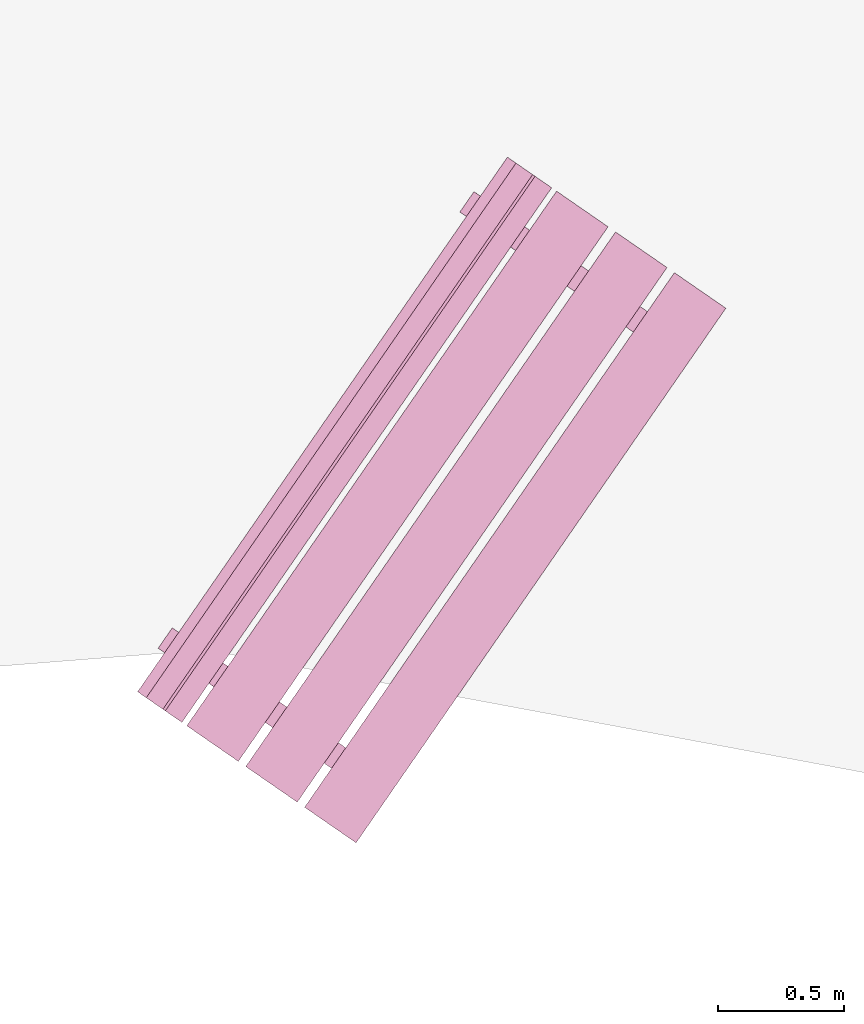
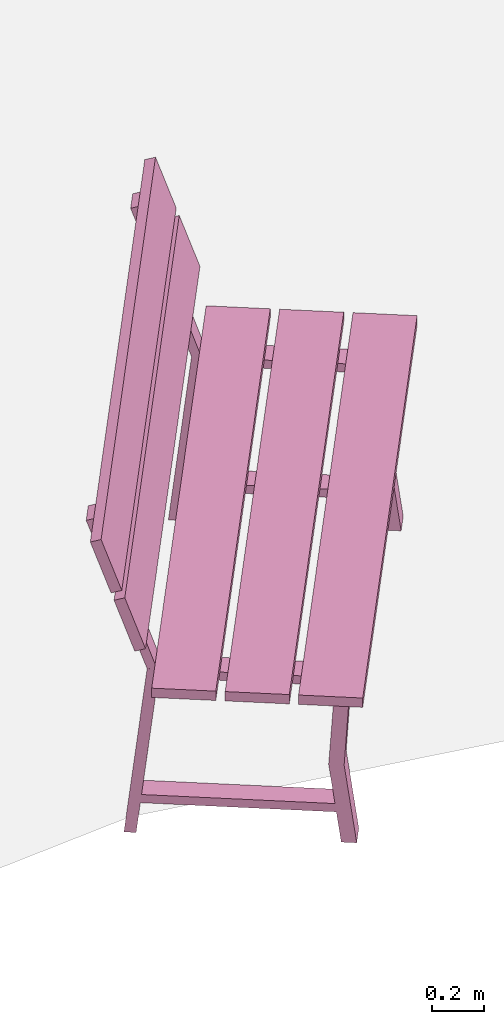
# One storey, part 13 of 200: 1 furnishing.
"""IFC4 building model written with IfcOpenShell, lengths in metres."""

import ifcopenshell
import ifcopenshell.guid

model = None  # the IFC model being written
_history = None  # IfcOwnerHistory: only IFC2X3 demands one
_inside = {}  # id of a spatial element -> (the spatial element, [elements in it])
_under = {}  # id of a project, library or spatial element -> (it, [spatial elements below it])
_declared = {}  # id of a project -> (the project, [libraries it declares])
_typed = {}  # id of a type object -> (the type object, [elements of that type])
_made_of = {}  # id of a material, layer set ... -> (it, [elements and type objects made of it])


def new_model(schema):
    """Start an empty IFC model of exactly this schema.

    Asked for "IFC4X3", IfcOpenShell would pick the latest addendum, in which some entities
    have other attributes; the version numbers below select the first issue.
    IFC2X3 requires an IfcOwnerHistory on every rooted entity: one is made here for all.
    """
    global model, _history
    if schema == "IFC4X3":
        model = ifcopenshell.file(schema_version=(4, 3, 0, 0))
    else:
        model = ifcopenshell.file(schema=schema)
    _inside.clear()
    _under.clear()
    _declared.clear()
    _typed.clear()
    _made_of.clear()
    _history = None
    if model.schema == "IFC2X3":
        org = make("IfcOrganization", Name="unknown")
        user = make(
            "IfcPersonAndOrganization",
            ThePerson=make("IfcPerson", FamilyName="unknown"),
            TheOrganization=org,
        )
        app = make(
            "IfcApplication",
            ApplicationDeveloper=org,
            Version="unknown",
            ApplicationFullName="unknown",
            ApplicationIdentifier="unknown",
        )
        _history = make(
            "IfcOwnerHistory",
            OwningUser=user,
            OwningApplication=app,
            ChangeAction="ADDED",
            CreationDate=0,
        )
    return model


def make(cls, **values):
    """One entity of the class cls with the attributes given. An attribute that is None is left unset."""
    return model.create_entity(
        cls, **{name: value for name, value in values.items() if value is not None}
    )


def rooted(cls, **values):
    """An entity with a GlobalId (a new one), such as an element, a storey or a relation."""
    return make(cls, GlobalId=ifcopenshell.guid.new(), OwnerHistory=_history, **values)


def si_unit(unit_type, name, prefix=None):
    """IfcSIUnit, for example si_unit("LENGTHUNIT", "METRE", prefix="MILLI")."""
    return make("IfcSIUnit", UnitType=unit_type, Prefix=prefix, Name=name)


def assignment(units):
    """IfcUnitAssignment: the units of a project."""
    return None if units is None else make("IfcUnitAssignment", Units=units)


def point(xyz):
    """IfcCartesianPoint."""
    return None if xyz is None else make("IfcCartesianPoint", Coordinates=xyz)


def direction(xyz):
    """IfcDirection."""
    return None if xyz is None else make("IfcDirection", DirectionRatios=xyz)


def frame(location, z_axis=None, x_axis=None):
    """IfcAxis2Placement3D, a coordinate frame: its origin and axes. An axis left out is left unset."""
    return make(
        "IfcAxis2Placement3D",
        Location=point(location),
        Axis=direction(z_axis),
        RefDirection=direction(x_axis),
    )


def origin_with_axes():
    """The frame at (0, 0, 0) with the z axis (0, 0, 1) and the x axis (1, 0, 0) written out."""
    return frame((0.0, 0.0, 0.0), z_axis=(0.0, 0.0, 1.0), x_axis=(1.0, 0.0, 0.0))


def place(relative_to, where):
    """IfcLocalPlacement: puts the frame where relative to a parent placement (None: the world)."""
    return make(
        "IfcLocalPlacement", PlacementRelTo=relative_to, RelativePlacement=where
    )


def context(
    kind, dimensions, precision=None, world=None, true_north=None, identifier=None
):
    """IfcGeometricRepresentationContext, for example the 3D "Model" context."""
    return make(
        "IfcGeometricRepresentationContext",
        ContextIdentifier=identifier,
        ContextType=kind,
        CoordinateSpaceDimension=dimensions,
        Precision=precision,
        WorldCoordinateSystem=world,
        TrueNorth=true_north,
    )


def subcontext(parent, identifier, kind, view, scale=None):
    """IfcGeometricRepresentationSubContext, for example "Body" below "Model"."""
    return make(
        "IfcGeometricRepresentationSubContext",
        ContextIdentifier=identifier,
        ContextType=kind,
        ParentContext=parent,
        TargetScale=scale,
        TargetView=view,
    )


def project(units=None, contexts=None):
    """IfcProject with its units and contexts."""
    return rooted(
        "IfcProject",
        Name="project",
        RepresentationContexts=contexts,
        UnitsInContext=assignment(units),
    )


def spatial(cls, under=None, at=None, **own):
    """A site, building, storey or space (cls), placed at a placement, below another one or the project."""
    s = rooted(cls, ObjectPlacement=at, **own)
    if under is not None:
        _under.setdefault(under.id(), (under, []))[1].append(s)
    return s


def point_list(points):
    """IfcCartesianPointList2D or 3D."""
    cls = (
        "IfcCartesianPointList2D" if len(points[0]) == 2 else "IfcCartesianPointList3D"
    )
    return make(cls, CoordList=points)


def triangles(points, corners, closed=None, point_numbers=None):
    """IfcTriangulatedFaceSet: each triangle names its three corners, points numbered from 1."""
    return make(
        "IfcTriangulatedFaceSet",
        Coordinates=point_list(points),
        Closed=closed,
        CoordIndex=corners,
        PnIndex=point_numbers,
    )


def shape(context_of_items, identifier, shape_type, items):
    """IfcShapeRepresentation: the items that make up one representation, for example the "Body"."""
    return make(
        "IfcShapeRepresentation",
        ContextOfItems=context_of_items,
        RepresentationIdentifier=identifier,
        RepresentationType=shape_type,
        Items=items,
    )


def material(Name=None, Category=None):
    """IfcMaterial."""
    return make("IfcMaterial", Name=Name, Category=Category)


def made_of(thing, what):
    """Note that an element or type object is made of a material, layer set ...; save() writes the relation."""
    if what is not None:
        _made_of.setdefault(what.id(), (what, []))[1].append(thing)
    return thing


def element(
    cls,
    number,
    at=None,
    inside=None,
    cuts=None,
    type_object=None,
    material=None,
    context=None,
    identifier="Body",
    shape_type=None,
    held_by="IfcProductDefinitionShape",
    body=None,
    shapes=None,
    **own,
):
    """One element of the class cls, such as IfcWall. Its Tag is "e" and its number.

    at: its placement. inside: the storey or other place that contains it. cuts: it is an
    opening in that element (IfcRelVoidsElement). A single representation is given by context,
    identifier, shape_type and body (its items); several are given by shapes. held_by: the class
    of the entity that holds the representations. save() writes the other relations.
    """
    e = rooted(cls, Tag="e%d" % number, ObjectPlacement=at, **own)
    if body is not None:
        shapes = [shape(context, identifier, shape_type, body)]
    if shapes is not None:
        e.Representation = make(held_by, Representations=shapes)
    if inside is not None:
        _inside.setdefault(inside.id(), (inside, []))[1].append(e)
    if cuts is not None:
        rooted(
            "IfcRelVoidsElement", RelatingBuildingElement=cuts, RelatedOpeningElement=e
        )
    if type_object is not None:
        _typed.setdefault(type_object.id(), (type_object, []))[1].append(e)
    return made_of(e, material)


def aggregate(whole, parts):
    """IfcRelAggregates: a whole, such as a stair, and the parts it consists of."""
    return rooted("IfcRelAggregates", RelatingObject=whole, RelatedObjects=parts)


def save(model, path):
    """Write the relations noted so far, then the file.

    IfcRelAggregates (storeys below a building ...), IfcRelContainedInSpatialStructure (elements
    in a storey), IfcRelDefinesByType, IfcRelAssociatesMaterial and IfcRelDeclares: one each for
    every whole, place, type object, material and project.
    """
    for whole, parts in _under.values():
        aggregate(whole, parts)
    for where, things in _inside.values():
        rooted(
            "IfcRelContainedInSpatialStructure",
            RelatedElements=things,
            RelatingStructure=where,
        )
    for kind, things in _typed.values():
        rooted("IfcRelDefinesByType", RelatedObjects=things, RelatingType=kind)
    for what, things in _made_of.values():
        rooted("IfcRelAssociatesMaterial", RelatedObjects=things, RelatingMaterial=what)
    for by, libraries in _declared.values():
        rooted("IfcRelDeclares", RelatingContext=by, RelatedDefinitions=libraries)
    model.write(path)


model = new_model("IFC4")

# Units and contexts
model_context = context("Model", 3, precision=1e-05, world=origin_with_axes())
body_context = subcontext(model_context, "Body", "Model", "MODEL_VIEW")
ifc_project = project(units=[si_unit("VOLUMEUNIT", "CUBIC_METRE"), si_unit("LENGTHUNIT", "METRE"), si_unit("AREAUNIT", "SQUARE_METRE")], contexts=[model_context])

# Site, building, storey
site_placement = place(None, origin_with_axes())
site = spatial("IfcSite", under=ifc_project, at=site_placement)
building_placement = place(site_placement, origin_with_axes())
building = spatial("IfcBuilding", under=site, at=building_placement, Name="Building")
storey_placement = place(building_placement, origin_with_axes())
storey = spatial("IfcBuildingStorey", under=building, at=storey_placement, Name="Ground")

# Furnishing
ifc_material = material(Name="bench")
furnishing_placement = place(storey_placement, origin_with_axes())
element("IfcFurnishingElement", 1, at=furnishing_placement, inside=storey, material=ifc_material, Name="cw_instances_bench_30", context=body_context, shape_type="Tessellation", body=[
    triangles([(433.6776323082832, -707.4828201764276, 0.815520754558246), (433.47344040222686, -707.3415949374371, 0.815520754558246), (432.0061604835972, -709.4630760936723, 0.815520754558246), (432.21035238965356, -709.6043013326628, 0.815520754558246), (432.4300447091276, -709.5270622097593, 0.36316797911391596), (432.4859863170098, -709.4461784837131, 0.36316797911391596), (432.52616392003955, -709.4739665175266, 1.4462435886752271e-07), (432.4702223121574, -709.5548502435728, 1.4462435886752271e-07), (432.5352831299738, -709.4802736362917, 0.36316797911391596), (432.51938698851654, -709.5888540065172, 1.6069373207502523e-07), (432.57532859639866, -709.507970280471, 1.6069373207502523e-07), (432.4793415220916, -709.5611573623379, 0.36316797911391596), (431.908433777329, -709.0467258461365, 0.7742224172068448), (431.908433777329, -709.0467258461365, 0.7742224172068448), (431.83455474513215, -708.9956288943528, 0.0), (431.77861313725, -709.076512620399, 0.0), (431.77861313725, -709.076512620399, 0.0), (431.85221795484034, -709.1280060480786, 0.7742224172068448), (431.943456995466, -709.0709489529537, 0.7346917591163886), (431.81733693365163, -709.1032951579983, 1.6069373207502518e-08), (431.8732785415338, -709.0224114319522, 1.6069373207502518e-08), (431.8875153875839, -709.1518326789999, 0.7353345501140619), (432.44986912509427, -709.5407733697009, 0.7353346465303011), (432.5060750590513, -709.4600724594862, 0.7346918555326278), (432.55576833469496, -709.4944418175306, 0.7742225618312036), (432.4995525122063, -709.5757220194728, 0.7742225618312036), (433.9111643822179, -707.6443379544353, 0.8155208509744852), (433.7069724893779, -707.5031127245855, 0.815520754558246), (432.2396925707483, -709.6245938808207, 0.815520754558246), (432.4438844635883, -709.7658191106705, 0.8155208509744852), (433.4437037188036, -707.321028156391, 0.815520754558246), (433.2395118259635, -707.1798029265412, 0.8155206581420068), (431.7722319073339, -709.3012840827764, 0.8155206581420068), (431.9764238001739, -709.4425093126262, 0.815520754558246), (433.21995168320655, -707.166274545868, 0.9999971268416286), (431.6867223560307, -709.2421431155756, 1.2349312667190762), (431.7526717645769, -709.2877557021031, 0.9999971268416286), (433.15400227466034, -707.1206619593404, 1.2349312667190762), (433.1444865227486, -707.1140805802648, 1.2691590637898031), (431.6112572220053, -709.1899491682541, 1.5040931072510113), (431.6772066041189, -709.2355617365, 1.2691590637898031), (433.0785371406349, -707.0684680120188, 1.5040931072510113), (431.65838533821056, -708.9935548956125, 1.4584561837579435), (431.71432700093743, -708.9126710902685, 1.4584561837579435), (431.908433777329, -709.0467258461365, 0.7742224172068448), (431.85221795484034, -709.1280060480786, 0.7742224172068448), (431.88407913539424, -709.1494560640493, 0.7739010297426947), (431.9396242673804, -709.0682981233967, 0.7739010297426947), (431.74564964081003, -708.9343347663038, 1.4724364581016047), (431.69010445397913, -709.0154927862542, 1.4724364581016047), (431.71844152466446, -709.2640810427804, 0.9858560302109066), (431.6526242659394, -709.2185598550278, 1.2207902665045935), (433.1857214432941, -707.1425998865452, 0.9858560302109066), (433.119904184569, -707.0970786987926, 1.2207902665045935), (431.64297637742277, -709.2118870863181, 1.2550180635753205), (431.57702698209283, -709.1662745089313, 1.4899522998690073), (433.1102562960524, -707.0904059300829, 1.2550180635753205), (433.04430690072246, -707.0447933526962, 1.4899522998690073), (433.62721419098153, -707.7961228952316, 0.36316797911391596), (433.6831557988637, -707.7152391691855, 0.36316797911391596), (433.7233334018934, -707.743027202999, 1.4462435886752271e-07), (433.6673917940113, -707.8239109290452, 1.4462435886752271e-07), (433.7324526118277, -707.7493343217641, 0.36316797911391596), (433.7165564703704, -707.8579146919895, 1.6069373207502523e-07), (433.77249807825257, -707.7770309659435, 1.6069373207502523e-07), (433.6765110039455, -707.8302180478103, 0.36316797911391596), (433.10560325918283, -707.3157865316089, 0.7742224172068448), (433.10560325918283, -707.3157865316089, 0.7742224172068448), (433.03172422698606, -707.2646895798251, 0.0), (432.9757826191039, -707.3455733058713, 0.0), (432.9757826191039, -707.3455733058713, 0.0), (433.0494788080468, -707.3969346233788, 0.7742224172068448), (433.1406264773199, -707.3400096384262, 0.7346917591163886), (433.01450641550554, -707.3723558434707, 1.6069373207502518e-08), (433.07044802338766, -707.2914721174245, 1.6069373207502518e-08), (433.08468486943775, -707.4208933644724, 0.7353345501140619), (433.6470386069482, -707.8098340551734, 0.7353346465303011), (433.7032445409052, -707.7291331449587, 0.7346918555326278), (433.75293781654887, -707.763502503003, 0.7742225618312036), (433.6968133654128, -707.8446505947729, 0.7742225618312036), (432.85564624626176, -707.2624833916149, 1.4584561837579435), (432.91149649193216, -707.1817317625247, 1.4584561837579435), (433.10560325918283, -707.3157865316089, 0.7742224172068448), (433.0494788080468, -707.3969346233788, 0.7742224172068448), (433.0812486172481, -707.4185167495218, 0.7739010297426947), (433.13679374923424, -707.3373588088691, 0.7739010297426947), (432.9428191318047, -707.2033954385598, 1.4724364581016047), (432.8873653620303, -707.2844212822566, 1.4724364581016047), (433.47344040222686, -707.3415949374371, 0.815520754558246), (432.0061604835972, -709.4630760936723, 0.7716513657017641), (432.0061604835972, -709.4630760936723, 0.815520754558246), (433.47344040222686, -707.3415949374371, 0.7716513657017641), (433.6776323082832, -707.4828201764276, 0.7716514139098837), (432.21035238965356, -709.6043013326628, 0.815520754558246), (432.21035238965356, -709.6043013326628, 0.7716514139098837), (433.6776323082832, -707.4828201764276, 0.815520754558246), (432.4702223121574, -709.5548502435728, 1.4462435886752271e-07), (432.4793415220916, -709.5611573623379, 0.36316797911391596), (432.4300447091276, -709.5270622097593, 0.36316797911391596), (432.51938698851654, -709.5888540065172, 1.6069373207502523e-07), (431.8875153875839, -709.1518326789999, 0.7353345501140619), (431.85221795484034, -709.1280060480786, 0.7742224172068448), (431.77861313725, -709.076512620399, 0.0), (431.81733693365163, -709.1032951579983, 1.6069373207502518e-08), (432.5352831299738, -709.4802736362917, 0.36316797911391596), (432.4859863170098, -709.4461784837131, 0.36316797911391596), (432.5060750590513, -709.4600724594862, 0.7346918555326278), (432.55576833469496, -709.4944418175306, 0.7742225618312036), (431.908433777329, -709.0467258461365, 0.7742224172068448), (431.943456995466, -709.0709489529537, 0.7346917591163886), (431.83455474513215, -708.9956288943528, 0.0), (431.8732785415338, -709.0224114319522, 1.6069373207502518e-08), (432.44986912509427, -709.5407733697009, 0.7353346465303011), (432.4995525122063, -709.5757220194728, 0.7742225618312036), (432.52616392003955, -709.4739665175266, 1.4462435886752271e-07), (432.57532859639866, -709.507970280471, 1.6069373207502523e-07), (431.65838533821056, -708.9935548956125, 1.4584561837579435), (431.74564964081003, -708.9343347663038, 1.4724364581016047), (431.71432700093743, -708.9126710902685, 1.4584561837579435), (431.69010445397913, -709.0154927862542, 1.4724364581016047), (431.8818900723114, -709.0297351090359, 0.13996424063734697), (431.8818900723114, -709.0297351090359, 0.17949489872780322), (432.5186515734662, -709.4701384380284, 0.13996438526170585), (432.5190480757948, -709.4704126709164, 0.17949504335216207), (431.8270453228552, -709.109032931498, 0.17949489872780322), (431.82722816610914, -709.1087685657742, 0.1406070155656471), (432.4637253544053, -709.5489890880759, 0.14060716019000596), (432.46420332633863, -709.5497104933786, 0.17949504335216207), (433.7069724893779, -707.5031127245855, 0.815520754558246), (432.2396925707483, -709.6245938808207, 0.7716514139098837), (432.2396925707483, -709.6245938808207, 0.815520754558246), (433.7069724893779, -707.5031127245855, 0.7716514139098837), (433.9111643822179, -707.6443379544353, 0.7716514621180032), (432.4438844635883, -709.7658191106705, 0.8155208509744852), (432.4438844635883, -709.7658191106705, 0.7716514621180032), (433.9111643822179, -707.6443379544353, 0.8155208509744852), (433.2395118259635, -707.1798029265412, 0.8155206581420068), (431.7722319073339, -709.3012840827764, 0.7716513174936444), (431.7722319073339, -709.3012840827764, 0.8155206581420068), (433.2395118259635, -707.1798029265412, 0.7716513174936444), (433.44370373201986, -707.3210281655317, 0.7716513657017641), (431.9764238001739, -709.4425093126262, 0.815520754558246), (431.9764238133902, -709.4425093217669, 0.7716513657017641), (433.4437037188036, -707.321028156391, 0.815520754558246), (431.6526242659394, -709.2185598550278, 1.2207902665045935), (433.15400227466034, -707.1206619593404, 1.2349312667190762), (433.119904184569, -707.0970786987926, 1.2207902665045935), (431.6867223560307, -709.2421431155756, 1.2349312667190762), (433.1857214432941, -707.1425998865452, 0.9858560302109066), (431.7526717645769, -709.2877557021031, 0.9999971268416286), (431.71844152466446, -709.2640810427804, 0.9858560302109066), (433.21995168320655, -707.166274545868, 0.9999971268416286), (431.57702698209283, -709.1662745089313, 1.4899522998690073), (433.0785371406349, -707.0684680120188, 1.5040931072510113), (433.04430690072246, -707.0447933526962, 1.4899522998690073), (431.6112572220053, -709.1899491682541, 1.5040931072510113), (433.1102562960524, -707.0904059300829, 1.2550180635753205), (431.6772066041189, -709.2355617365, 1.2691590637898031), (431.64297637742277, -709.2118870863181, 1.2550180635753205), (433.1444865227486, -707.1140805802648, 1.2691590637898031), (433.6673917940113, -707.8239109290452, 1.4462435886752271e-07), (433.6765110039455, -707.8302180478103, 0.36316797911391596), (433.62721419098153, -707.7961228952316, 0.36316797911391596), (433.7165564703704, -707.8579146919895, 1.6069373207502523e-07), (433.08468486943775, -707.4208933644724, 0.7353345501140619), (433.0494788080468, -707.3969346233788, 0.7742224172068448), (432.9757826191039, -707.3455733058713, 0.0), (433.01450641550554, -707.3723558434707, 1.6069373207502518e-08), (433.7324526118277, -707.7493343217641, 0.36316797911391596), (433.6831557988637, -707.7152391691855, 0.36316797911391596), (433.7032445409052, -707.7291331449587, 0.7346918555326278), (433.75293781654887, -707.763502503003, 0.7742225618312036), (433.10560325918283, -707.3157865316089, 0.7742224172068448), (433.1406264773199, -707.3400096384262, 0.7346917591163886), (433.03172422698606, -707.2646895798251, 0.0), (433.07044802338766, -707.2914721174245, 1.6069373207502518e-08), (433.6470386069482, -707.8098340551734, 0.7353346465303011), (433.6968133654128, -707.8446505947729, 0.7742225618312036), (433.7233334018934, -707.743027202999, 1.4462435886752271e-07), (433.77249807825257, -707.7770309659435, 1.6069373207502523e-07), (432.85564624626176, -707.2624833916149, 1.4584561837579435), (432.9428191318047, -707.2033954385598, 1.4724364581016047), (432.91149649193216, -707.1817317625247, 1.4584561837579435), (432.8873653620303, -707.2844212822566, 1.4724364581016047), (433.07915098036267, -707.2986636050382, 0.13996424063734697), (433.07915098036267, -707.2986636050382, 0.17949489872780322), (433.7159124815174, -707.7390669340307, 0.13996438526170585), (433.71630898384603, -707.7393411669187, 0.17949504335216207), (433.0242148047091, -707.3780936169704, 0.17949489872780322), (433.02448901931564, -707.3776971410743, 0.1406070155656471), (433.6609862076118, -707.8179176633762, 0.14060716019000596), (433.6613728081925, -707.818771178851, 0.17949504335216207), (433.6776323082832, -707.4828201764276, 0.815520754558246), (433.47344040222686, -707.3415949374371, 0.7716513657017641), (433.47344040222686, -707.3415949374371, 0.815520754558246), (433.6776323082832, -707.4828201764276, 0.7716514139098837), (432.0061604835972, -709.4630760936723, 0.815520754558246), (432.0061604835972, -709.4630760936723, 0.7716513657017641), (432.21035238965356, -709.6043013326628, 0.7716514139098837), (432.21035238965356, -709.6043013326628, 0.815520754558246), (433.9111643822179, -707.6443379544353, 0.8155208509744852), (433.7069724893779, -707.5031127245855, 0.7716514139098837), (433.7069724893779, -707.5031127245855, 0.815520754558246), (433.9111643822179, -707.6443379544353, 0.7716514621180032), (432.2396925707483, -709.6245938808207, 0.815520754558246), (432.2396925707483, -709.6245938808207, 0.7716514139098837), (432.4438844635883, -709.7658191106705, 0.7716514621180032), (432.4438844635883, -709.7658191106705, 0.8155208509744852), (433.4437037188036, -707.321028156391, 0.815520754558246), (433.2395118259635, -707.1798029265412, 0.7716513174936444), (433.2395118259635, -707.1798029265412, 0.8155206581420068), (433.44370373201986, -707.3210281655317, 0.7716513657017641), (431.7722319073339, -709.3012840827764, 0.8155206581420068), (431.7722319073339, -709.3012840827764, 0.7716513174936444), (431.9764238133902, -709.4425093217669, 0.7716513657017641), (431.9764238001739, -709.4425093126262, 0.815520754558246), (433.1857214432941, -707.1425998865452, 0.9858560302109066), (433.119904184569, -707.0970786987926, 1.2207902665045935), (433.15400227466034, -707.1206619593404, 1.2349312667190762), (433.21995168320655, -707.166274545868, 0.9999971268416286), (431.6867223560307, -709.2421431155756, 1.2349312667190762), (431.71844152466446, -709.2640810427804, 0.9858560302109066), (431.7526717645769, -709.2877557021031, 0.9999971268416286), (431.6526242659394, -709.2185598550278, 1.2207902665045935), (433.1102562960524, -707.0904059300829, 1.2550180635753205), (433.04430690072246, -707.0447933526962, 1.4899522998690073), (433.0785371406349, -707.0684680120188, 1.5040931072510113), (433.1444865227486, -707.1140805802648, 1.2691590637898031), (431.6112572220053, -709.1899491682541, 1.5040931072510113), (431.64297637742277, -709.2118870863181, 1.2550180635753205), (431.6772066041189, -709.2355617365, 1.2691590637898031), (431.57702698209283, -709.1662745089313, 1.4899522998690073), (431.9396242673804, -709.0682981233967, 0.7739010297426947), (431.74564964081003, -708.9343347663038, 1.4724364581016047), (431.71432700093743, -708.9126710902685, 1.4584561837579435), (431.85221795484034, -709.1280060480786, 0.7742224172068448), (431.88407913539424, -709.1494560640493, 0.7739010297426947), (431.69010445397913, -709.0154927862542, 1.4724364581016047), (431.65838533821056, -708.9935548956125, 1.4584561837579435), (433.13679374923424, -707.3373588088691, 0.7739010297426947), (432.9428191318047, -707.2033954385598, 1.4724364581016047), (432.91149649193216, -707.1817317625247, 1.4584561837579435), (433.0494788080468, -707.3969346233788, 0.7742224172068448), (433.0812486172481, -707.4185167495218, 0.7739010297426947), (432.8873653620303, -707.2844212822566, 1.4724364581016047), (432.85564624626176, -707.2624833916149, 1.4584561837579435), (431.908433777329, -709.0467258461365, 0.7742224172068448), (431.85221795484034, -709.1280060480786, 0.7742224172068448), (432.55576833469496, -709.4944418175306, 0.7742225618312036), (432.4995525122063, -709.5757220194728, 0.7742225618312036), (431.8818900723114, -709.0297351090359, 0.17949489872780322), (431.8270453228552, -709.109032931498, 0.17949489872780322), (432.5190480757948, -709.4704126709164, 0.17949504335216207), (432.46420332633863, -709.5497104933786, 0.17949504335216207), (433.10560325918283, -707.3157865316089, 0.7742224172068448), (433.0494788080468, -707.3969346233788, 0.7742224172068448), (433.75293781654887, -707.763502503003, 0.7742225618312036), (433.6968133654128, -707.8446505947729, 0.7742225618312036), (433.07915098036267, -707.2986636050382, 0.17949489872780322), (433.0242148047091, -707.3780936169704, 0.17949489872780322), (433.71630898384603, -707.7393411669187, 0.17949504335216207), (433.6613728081925, -707.818771178851, 0.17949504335216207)], [[1, 2, 3], [3, 4, 1], [5, 6, 7], [7, 8, 5], [9, 10, 11], [10, 9, 12], [14, 15, 16], [17, 18, 13], [19, 20, 21], [20, 19, 22], [23, 24, 5], [24, 6, 5], [12, 9, 25], [25, 26, 12], [27, 28, 29], [29, 30, 27], [31, 32, 33], [33, 34, 31], [35, 36, 37], [35, 38, 36], [39, 40, 41], [39, 42, 40], [43, 44, 45], [45, 46, 43], [47, 48, 49], [49, 50, 47], [51, 52, 53], [54, 53, 52], [55, 56, 57], [58, 57, 56], [59, 60, 61], [61, 62, 59], [63, 64, 65], [64, 63, 66], [68, 69, 71], [70, 72, 67], [73, 74, 75], [74, 73, 76], [77, 78, 59], [78, 60, 59], [66, 63, 79], [79, 80, 66], [81, 82, 83], [83, 84, 81], [85, 86, 87], [87, 88, 85], [89, 90, 91], [89, 92, 90], [93, 94, 95], [93, 96, 94], [97, 98, 99], [97, 100, 98], [101, 102, 103], [103, 104, 101], [105, 106, 107], [107, 108, 105], [109, 110, 111], [110, 112, 111], [108, 107, 109], [107, 110, 109], [113, 99, 98], [98, 114, 113], [115, 106, 105], [105, 116, 115], [117, 118, 119], [117, 120, 118], [102, 101, 113], [113, 114, 102], [121, 122, 123], [122, 124, 123], [125, 126, 127], [127, 128, 125], [129, 130, 131], [129, 132, 130], [133, 134, 135], [133, 136, 134], [137, 138, 139], [137, 140, 138], [141, 142, 143], [141, 144, 142], [145, 146, 147], [145, 148, 146], [149, 150, 151], [149, 152, 150], [153, 154, 155], [153, 156, 154], [157, 158, 159], [157, 160, 158], [161, 162, 163], [161, 164, 162], [165, 166, 167], [167, 168, 165], [169, 170, 171], [171, 172, 169], [173, 174, 175], [174, 176, 175], [172, 171, 173], [171, 174, 173], [177, 163, 162], [162, 178, 177], [179, 170, 169], [169, 180, 179], [181, 182, 183], [181, 184, 182], [166, 165, 177], [177, 178, 166], [185, 186, 187], [186, 188, 187], [189, 190, 191], [191, 192, 189], [193, 194, 195], [194, 193, 196], [197, 198, 199], [199, 200, 197], [201, 202, 203], [202, 201, 204], [205, 206, 207], [207, 208, 205], [209, 210, 211], [210, 209, 212], [213, 214, 215], [215, 216, 213], [217, 218, 219], [219, 220, 217], [221, 222, 223], [222, 221, 224], [225, 226, 227], [227, 228, 225], [229, 230, 231], [230, 229, 232], [233, 109, 234], [109, 235, 234], [236, 237, 238], [238, 239, 236], [240, 173, 241], [173, 242, 241], [243, 244, 245], [245, 246, 243], [247, 248, 249], [248, 250, 249], [251, 252, 253], [252, 254, 253], [255, 256, 257], [256, 258, 257], [259, 260, 261], [260, 262, 261]], closed=True),
])

save(model, "model.ifc")
